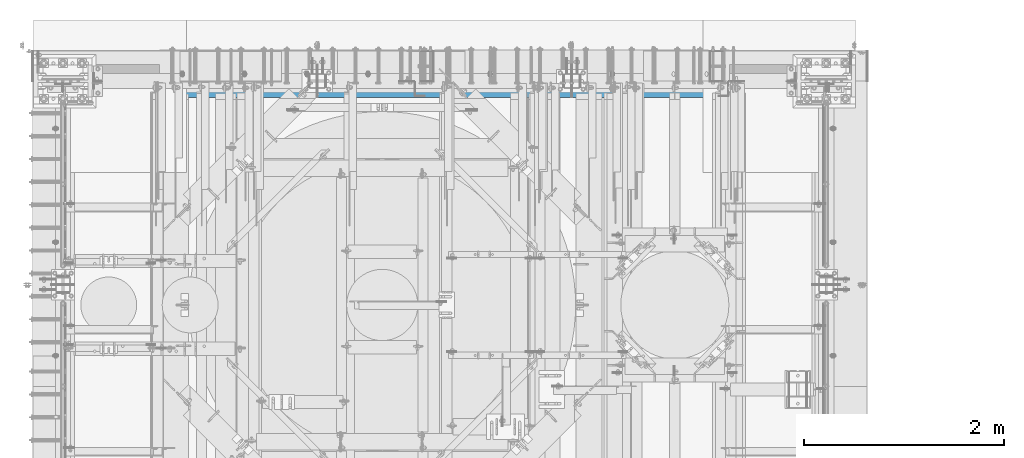
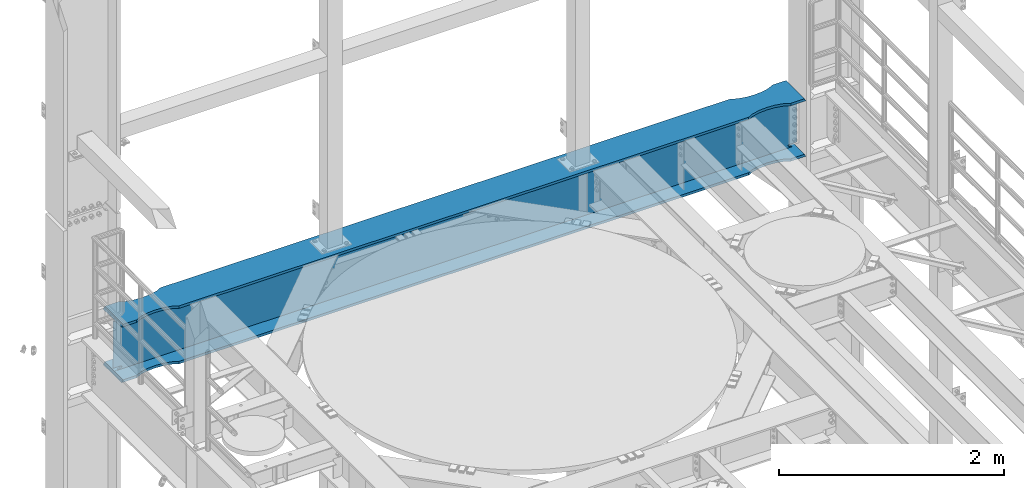
# One storey, part 1066 of 1876: 1 beam, 1 element without a shape of its own.
"""IFC2X3 building model written with IfcOpenShell, lengths in millimetres."""

from ifc_helpers import new_model, si_unit, frame, origin_with_axes, place, context, subcontext, project, spatial, faceted_brep, material, type_object, element, aggregate, save


model = new_model("IFC2X3")

# Units and contexts
model_context = context("Model", 3, precision=1e-05, world=origin_with_axes())
body_context = subcontext(model_context, "Body", "Model", "MODEL_VIEW")
ifc_project = project(units=[si_unit("LENGTHUNIT", "METRE", prefix="MILLI"), si_unit("AREAUNIT", "SQUARE_METRE"), si_unit("VOLUMEUNIT", "CUBIC_METRE"), si_unit("MASSUNIT", "GRAM", prefix="KILO"), si_unit("TIMEUNIT", "SECOND"), si_unit("PLANEANGLEUNIT", "RADIAN"), si_unit("SOLIDANGLEUNIT", "STERADIAN"), si_unit("THERMODYNAMICTEMPERATUREUNIT", "DEGREE_CELSIUS"), si_unit("LUMINOUSINTENSITYUNIT", "LUMEN")], contexts=[model_context])

# Site, building, storey
site_placement = place(None, origin_with_axes())
site = spatial("IfcSite", under=ifc_project, at=site_placement, CompositionType="ELEMENT")
building_placement = place(site_placement, origin_with_axes())
building = spatial("IfcBuilding", under=site, at=building_placement, Name="Undefined", CompositionType="ELEMENT")
storey_placement = place(building_placement, origin_with_axes())
storey = spatial("IfcBuildingStorey", under=building, at=storey_placement, Name="Undefined", CompositionType="ELEMENT", Elevation=0.0)

# Assembly, beam
assembly_placement = place(storey_placement, origin_with_axes())
assembly = element("IfcElementAssembly", 1, at=assembly_placement, inside=storey, Name="BEAM", AssemblyPlace="NOTDEFINED", PredefinedType="RIGID_FRAME")
ifc_material = material(Name="STEEL/A992")
beam_type = type_object("IfcBeamType", Name="W24X146", PredefinedType="NOTDEFINED")
beam_placement = place(assembly_placement, frame((0.0, 13716.0, 12995.275), z_axis=(0.0, 0.0, 1.0), x_axis=(1.0, 0.0, 0.0)))
beam = element("IfcBeam", 2, at=beam_placement, type_object=beam_type, material=ifc_material, Name="BEAM", ObjectType="W24X146", context=body_context, shape_type="Brep", body=[
    faceted_brep([(7318.375, -7.9375, -252.4125), (7308.85, 7.9375, -252.4125), (7308.85, 7.9375, 252.4125), (7318.375, -7.9375, 252.4125), (311.15, 7.9375, -252.4125), (301.625, -7.9375, -252.4125), (301.625, -7.9375, 252.4125), (311.15, 7.9375, 252.4125), (6787.05722612347, 136.155854771378, 314.325000000001), (6787.05722612347, 136.155854771378, 287.3375), (6731.00000871499, 163.5125, 287.3375), (6731.00000871499, 163.512500299129, 314.325000000001), (6787.48805720929, 135.961267957882, 314.325000000001), (6787.48805720929, 135.961267957882, 287.3375), (6787.92970812774, 135.792674011595, 314.325000000001), (6787.92970812774, 135.792674011595, 287.3375), (6788.3806123108, 135.650670947547, 314.325000000001), (6788.3806123108, 135.650670947547, 287.3375), (6788.83917036842, 135.535762460966, 314.325000000001), (6788.83917036842, 135.535762460966, 287.3375), (6866.57612824297, 118.499041238055, 314.325000000001), (6866.57612824297, 118.499041238055, 287.3375), (6946.90001329237, 112.712500184298, 314.325000000001), (6946.90001329237, 112.712500184298, 287.3375), (7027.22389842007, 118.4990401514, 314.325000000001), (7027.22389842007, 118.4990401514, 287.3375), (7105.88894087753, 135.739157957359, 314.325000000001), (7105.88894087753, 135.739157957359, 287.3375), (7162.80000000007, 163.512504557366, 314.325000000001), (7162.80000000007, 163.5125, 287.3375), (6787.05722612347, 136.155854771378, -287.3375), (6787.05722612347, 136.155854771378, -314.325000000001), (6731.00000871499, 163.5125, -314.325000000001), (6731.00000871499, 163.512500299129, -287.3375), (6787.48805720929, 135.961267957882, -287.3375), (6787.48805720929, 135.961267957882, -314.325000000001), (6787.92970812774, 135.792674011595, -287.3375), (6787.92970812774, 135.792674011595, -314.325000000001), (6788.3806123108, 135.650670947547, -287.3375), (6788.3806123108, 135.650670947547, -314.325000000001), (6788.83917036842, 135.535762460966, -287.3375), (6788.83917036842, 135.535762460966, -314.325000000001), (6866.57612824297, 118.499041238055, -287.3375), (6866.57612824297, 118.499041238055, -314.325000000001), (6946.90001329237, 112.712500184298, -287.3375), (6946.90001329237, 112.712500184298, -314.325000000001), (7027.22389842007, 118.4990401514, -287.3375), (7027.22389842007, 118.4990401514, -314.325000000001), (7105.88894087753, 135.739157957359, -287.3375), (7105.88894087753, 135.739157957359, -314.325000000001), (7162.80000000007, 163.512504557366, -287.3375), (7162.80000000007, 163.5125, -314.325000000001), (7162.80000000007, -163.512501991139, -287.3375), (7162.80000000007, -163.5125, -314.325000000001), (7318.375, -163.5125, -314.325000000001), (7302.79341467604, -163.512500199422, -287.3375), (7162.80000000007, -163.512501991139, 314.325000000001), (7162.80000000007, -163.5125, 287.3375), (7318.375, -163.5125, 287.3375), (7302.79342652469, -163.512500199422, 314.325000000001), (7265.82200317383, -7.9375, -286.94049987793), (7265.82200317383, 7.9375, -286.94049987793), (7230.34974885072, 7.9375, -270.587562630286), (7230.34974885072, -7.9375, -270.587562630286), (7226.45954094452, 7.9375, -267.291342989443), (7226.45954094452, -7.9375, -267.291342989443), (7224.82687519741, 7.9375, -262.460899528196), (7224.82687519741, -7.9375, -262.460899528196), (7225.91961637614, 7.9375, -257.48046800167), (7225.91961637614, -7.9375, -257.48046800167), (7229.42462316711, 7.9375, -253.777265486369), (7229.42462316711, -7.9375, -253.777265486369), (7234.33748349907, 7.9375, -252.4125), (7234.33748349907, -7.9375, -252.4125), (7234.50248497622, 7.9375, 252.4125), (7234.50248497622, -7.9375, 252.4125), (7229.58962470748, 7.9375, 253.777265448316), (7229.58962470748, -7.9375, 253.777265448316), (7226.08461792234, 7.9375, 257.480467871263), (7226.08461792234, -7.9375, 257.480467871263), (7224.9918766624, 7.9375, 262.460899307192), (7224.9918766624, -7.9375, 262.460899307192), (7226.6245422558, 7.9375, 267.291342745357), (7226.6245422558, -7.9375, 267.291342745357), (7230.51474999286, 7.9375, 270.587562475843), (7230.51474999286, -7.9375, 270.587562475843), (7265.9870010376, 7.9375, 286.94049987793), (7265.9870010376, -7.9375, 286.94049987793), (7318.375, 7.9375, 286.94049987793), (7318.375, -7.9375, 286.94049987793), (7318.375, 7.9375, 287.3375), (7318.375, -7.9375, 287.3375), (7318.375, 163.5125, 287.3375), (7302.79342652469, 163.512500456442, 314.325000000001), (457.199999305522, 163.5125, 314.325000000001), (457.199999305522, 163.5125, 287.3375), (301.625, 163.5125, 287.3375), (317.206573475306, 163.5125, 314.325000000001), (513.257216713985, 136.155853488265, 314.325000000001), (513.257216713985, 136.155853488265, 287.3375), (513.688047799806, 135.961266674769, 314.325000000001), (513.688047799806, 135.961266674769, 287.3375), (514.12969871826, 135.792672728482, 314.325000000001), (514.12969871826, 135.792672728482, 287.3375), (514.580602901315, 135.650669664434, 314.325000000001), (514.580602901315, 135.650669664434, 287.3375), (515.039160958935, 135.535761177853, 314.325000000001), (515.039160958935, 135.535761177853, 287.3375), (592.776118833464, 118.499039954942, 314.325000000001), (592.776118833464, 118.499039954942, 287.3375), (673.100003882856, 112.712498901185, 314.325000000001), (673.100003882856, 112.712498901185, 287.3375), (753.423889010533, 118.499038868286, 314.325000000001), (753.423889010533, 118.499038868286, 287.3375), (832.088931467987, 135.739156674245, 314.325000000001), (832.088931467987, 135.739156674245, 287.3375), (888.999990590519, 163.512503274253, 314.325000000001), (888.999990590519, 163.5125, 287.3375), (301.625, 7.9375, 287.3375), (317.206573475306, -163.5125, 314.325000000001), (457.199999305522, -163.5125, 314.325000000001), (513.257216713985, -136.155853488265, 314.325000000001), (513.688047799806, -135.961266674769, 314.325000000001), (514.12969871826, -135.792672728482, 314.325000000001), (514.580602901315, -135.650669664434, 314.325000000001), (515.039160958935, -135.535761177853, 314.325000000001), (592.776118833464, -118.499039954942, 314.325000000001), (673.100003882856, -112.712498901185, 314.325000000001), (753.423889010533, -118.499038868286, 314.325000000001), (832.088931467987, -135.739156674245, 314.325000000001), (888.999990590519, -163.512503274253, 314.325000000001), (6731.00000871499, -163.512500299129, 314.325000000001), (6787.05722612347, -136.155852205152, 314.325000000001), (6787.48805720929, -135.961265391656, 314.325000000001), (6787.92970812774, -135.792671445369, 314.325000000001), (6788.3806123108, -135.65066838132, 314.325000000001), (6788.83917036842, -135.535759894739, 314.325000000001), (6866.57612824297, -118.499038671828, 314.325000000001), (6946.90001329237, -112.712497618071, 314.325000000001), (7027.22389842007, -118.499037585173, 314.325000000001), (7105.88894087753, -135.739155391132, 314.325000000001), (457.199999305522, -163.5125, 287.3375), (301.625, -163.5125, 287.3375), (513.257216713985, -136.155853488265, 287.3375), (513.688047799806, -135.961266674769, 287.3375), (514.12969871826, -135.792672728482, 287.3375), (514.580602901315, -135.650669664434, 287.3375), (515.039160958935, -135.535761177853, 287.3375), (592.776118833464, -118.499039954942, 287.3375), (673.100003882856, -112.712498901185, 287.3375), (753.423889010533, -118.499038868286, 287.3375), (832.088931467987, -135.739156674245, 287.3375), (888.999990590519, -163.5125, 287.3375), (6731.00000871499, -163.5125, 287.3375), (6787.05722612347, -136.155852205152, 287.3375), (6787.48805720929, -135.961265391656, 287.3375), (6787.92970812774, -135.792671445369, 287.3375), (6788.3806123108, -135.65066838132, 287.3375), (6788.83917036842, -135.535759894739, 287.3375), (6866.57612824297, -118.499038671828, 287.3375), (6946.90001329237, -112.712497618071, 287.3375), (7027.22389842007, -118.499037585173, 287.3375), (7105.88894087753, -135.739155391132, 287.3375), (301.625, -7.9375, 287.3375), (301.625, 7.9375, 286.94049987793), (301.625, -7.9375, 286.94049987793), (354.012998962403, 7.9375, 286.94049987793), (354.012998962403, -7.9375, 286.94049987793), (389.485250007137, 7.9375, 270.587562475845), (389.485250007137, -7.9375, 270.587562475845), (393.375457744202, 7.9375, 267.291342745357), (393.375457744202, -7.9375, 267.291342745357), (395.008123337595, 7.9375, 262.460899307192), (395.008123337595, -7.9375, 262.460899307192), (393.915382077658, 7.9375, 257.480467871263), (393.915382077658, -7.9375, 257.480467871263), (390.410375292523, 7.9375, 253.777265448314), (390.410375292523, -7.9375, 253.777265448314), (385.497515023773, 7.9375, 252.412500000002), (385.497515023773, -7.9375, 252.412500000002), (385.66251650093, 7.9375, -252.4125), (385.66251650093, -7.9375, -252.4125), (390.575376832887, 7.9375, -253.777265486369), (390.575376832887, -7.9375, -253.777265486369), (394.08038362386, 7.9375, -257.48046800167), (394.08038362386, -7.9375, -257.48046800167), (395.173124802588, 7.9375, -262.460899528196), (395.173124802588, -7.9375, -262.460899528196), (393.540459055476, 7.9375, -267.291342989443), (393.540459055476, -7.9375, -267.291342989443), (389.650251149281, 7.9375, -270.587562630286), (389.650251149281, -7.9375, -270.587562630286), (354.177996826172, 7.9375, -286.94049987793), (354.177996826172, -7.9375, -286.94049987793), (317.435792427282, 7.9375, -286.94049987793), (317.435792427282, -7.9375, -286.94049987793), (7302.79341467604, -7.9375, -287.3375), (7302.56420757272, -7.9375, -286.94049987793), (317.206585323961, -7.9375, -287.3375), (7302.56420757272, 7.9375, -286.94049987793), (7302.79341467604, 7.9375, -287.3375), (317.206585323961, 7.9375, -287.3375), (888.999990590519, 163.512503274253, -287.3375), (888.999990590519, 163.5125, -314.325000000001), (832.088931467987, 135.739156674245, -314.325000000001), (832.088931467987, 135.739156674245, -287.3375), (753.423889010533, 118.499038868286, -314.325000000001), (753.423889010533, 118.499038868286, -287.3375), (673.100003882856, 112.712498901185, -314.325000000001), (673.100003882856, 112.712498901185, -287.3375), (592.776118833464, 118.499039954942, -314.325000000001), (592.776118833464, 118.499039954942, -287.3375), (515.039160958935, 135.535761177853, -314.325000000001), (515.039160958935, 135.535761177853, -287.3375), (514.580602901315, 135.650669664434, -314.325000000001), (514.580602901315, 135.650669664434, -287.3375), (514.12969871826, 135.792672728482, -314.325000000001), (514.12969871826, 135.792672728482, -287.3375), (513.688047799806, 135.961266674769, -314.325000000001), (513.688047799806, 135.961266674769, -287.3375), (513.257216713985, 136.155853488265, -314.325000000001), (513.257216713985, 136.155853488265, -287.3375), (457.199999305522, 163.5125, -314.325000000001), (457.199999305522, 163.5125, -287.3375), (301.625, 163.5125, -314.325000000001), (317.206585323961, 163.5125, -287.3375), (301.625, -163.5125, -314.325000000001), (317.206585323961, -163.5125, -287.3375), (457.199999305522, -163.5125, -314.325000000001), (457.199999305522, -163.5125, -287.3375), (513.257216713985, -136.155853488265, -314.325000000001), (513.257216713985, -136.155853488265, -287.3375), (513.688047799806, -135.961266674769, -314.325000000001), (513.688047799806, -135.961266674769, -287.3375), (514.12969871826, -135.792672728482, -314.325000000001), (514.12969871826, -135.792672728482, -287.3375), (514.580602901315, -135.650669664434, -314.325000000001), (514.580602901315, -135.650669664434, -287.3375), (515.039160958935, -135.535761177853, -314.325000000001), (515.039160958935, -135.535761177853, -287.3375), (592.776118833464, -118.499039954942, -314.325000000001), (592.776118833464, -118.499039954942, -287.3375), (673.100003882856, -112.712498901185, -314.325000000001), (673.100003882856, -112.712498901185, -287.3375), (753.423889010533, -118.499038868286, -314.325000000001), (753.423889010533, -118.499038868286, -287.3375), (832.088931467987, -135.739156674245, -314.325000000001), (832.088931467987, -135.739156674245, -287.3375), (888.999990590519, -163.512503274253, -287.3375), (888.999990590519, -163.5125, -314.325000000001), (6731.00000871499, -163.5125, -314.325000000001), (6731.00000871499, -163.512500299129, -287.3375), (6787.05722612347, -136.155852205152, -314.325000000001), (6787.05722612347, -136.155852205152, -287.3375), (6787.48805720929, -135.961265391656, -314.325000000001), (6787.48805720929, -135.961265391656, -287.3375), (6787.92970812774, -135.792671445369, -314.325000000001), (6787.92970812774, -135.792671445369, -287.3375), (6788.3806123108, -135.65066838132, -314.325000000001), (6788.3806123108, -135.65066838132, -287.3375), (6788.83917036842, -135.535759894739, -314.325000000001), (6788.83917036842, -135.535759894739, -287.3375), (6866.57612824297, -118.499038671828, -314.325000000001), (6866.57612824297, -118.499038671828, -287.3375), (6946.90001329237, -112.712497618071, -314.325000000001), (6946.90001329237, -112.712497618071, -287.3375), (7027.22389842007, -118.499037585173, -314.325000000001), (7027.22389842007, -118.499037585173, -287.3375), (7105.88894087753, -135.739155391132, -314.325000000001), (7105.88894087753, -135.739155391132, -287.3375), (7318.375, 163.5125, -314.325000000001), (7302.79341467604, 163.512500456442, -287.3375)], [[[0, 1, 2, 3]], [[4, 5, 6, 7]], [[8, 9, 10, 11]], [[12, 13, 9, 8]], [[14, 15, 13, 12]], [[16, 17, 15, 14]], [[18, 19, 17, 16]], [[20, 21, 19, 18]], [[22, 23, 21, 20]], [[24, 25, 23, 22]], [[26, 27, 25, 24]], [[28, 29, 27, 26]], [[30, 31, 32, 33]], [[34, 35, 31, 30]], [[36, 37, 35, 34]], [[38, 39, 37, 36]], [[40, 41, 39, 38]], [[42, 43, 41, 40]], [[44, 45, 43, 42]], [[46, 47, 45, 44]], [[48, 49, 47, 46]], [[50, 51, 49, 48]], [[52, 53, 54, 55]], [[56, 57, 58, 59]], [[60, 61, 62, 63]], [[63, 62, 64, 65]], [[65, 64, 66, 67]], [[67, 66, 68, 69]], [[69, 68, 70, 71]], [[71, 70, 72, 73]], [[73, 72, 1, 0]], [[74, 75, 3, 2]], [[75, 74, 76, 77]], [[77, 76, 78, 79]], [[79, 78, 80, 81]], [[81, 80, 82, 83]], [[83, 82, 84, 85]], [[85, 84, 86, 87]], [[87, 86, 88, 89]], [[89, 88, 90, 91]], [[58, 91, 90, 92, 93, 59]], [[94, 95, 96, 97]], [[98, 99, 95, 94]], [[100, 101, 99, 98]], [[102, 103, 101, 100]], [[104, 105, 103, 102]], [[106, 107, 105, 104]], [[108, 109, 107, 106]], [[110, 111, 109, 108]], [[112, 113, 111, 110]], [[114, 115, 113, 112]], [[116, 117, 115, 114]], [[117, 116, 11, 10]], [[118, 96, 95, 99, 101, 103, 105, 107, 109, 111, 113, 115, 117, 10, 9, 13, 15, 17, 19, 21, 23, 25, 27, 29, 92, 90]], [[29, 28, 93, 92]], [[28, 26, 24, 22, 20, 18, 16, 14, 12, 8, 11, 116, 114, 112, 110, 108, 106, 104, 102, 100, 98, 94, 97, 119, 120, 121, 122, 123, 124, 125, 126, 127, 128, 129, 130, 131, 132, 133, 134, 135, 136, 137, 138, 139, 140, 56, 59, 93]], [[141, 120, 119, 142]], [[120, 141, 143, 121]], [[121, 143, 144, 122]], [[122, 144, 145, 123]], [[123, 145, 146, 124]], [[124, 146, 147, 125]], [[125, 147, 148, 126]], [[126, 148, 149, 127]], [[127, 149, 150, 128]], [[128, 150, 151, 129]], [[130, 129, 151, 152]], [[130, 152, 153, 131]], [[131, 153, 154, 132]], [[132, 154, 155, 133]], [[133, 155, 156, 134]], [[134, 156, 157, 135]], [[135, 157, 158, 136]], [[136, 158, 159, 137]], [[137, 159, 160, 138]], [[138, 160, 161, 139]], [[139, 161, 162, 140]], [[56, 140, 162, 57]], [[57, 162, 161, 160, 159, 158, 157, 156, 155, 154, 153, 152, 151, 150, 149, 148, 147, 146, 145, 144, 143, 141, 142, 163, 91, 58]], [[119, 97, 96, 118, 163, 142]], [[164, 165, 163, 118]], [[166, 167, 165, 164]], [[167, 166, 168, 169]], [[169, 168, 170, 171]], [[171, 170, 172, 173]], [[173, 172, 174, 175]], [[175, 174, 176, 177]], [[177, 176, 178, 179]], [[179, 178, 7, 6]], [[180, 181, 5, 4]], [[181, 180, 182, 183]], [[183, 182, 184, 185]], [[185, 184, 186, 187]], [[187, 186, 188, 189]], [[189, 188, 190, 191]], [[191, 190, 192, 193]], [[193, 192, 194, 195]], [[196, 197, 60, 63, 65, 67, 69, 71, 73, 0, 3, 75, 77, 79, 81, 83, 85, 87, 89, 91, 163, 165, 167, 169, 171, 173, 175, 177, 179, 6, 5, 181, 183, 185, 187, 189, 191, 193, 195, 198]], [[61, 60, 197, 199]], [[72, 70, 68, 66, 64, 62, 61, 199, 200, 201, 194, 192, 190, 188, 186, 184, 182, 180, 4, 7, 178, 176, 174, 172, 170, 168, 166, 164, 118, 90, 88, 86, 84, 82, 80, 78, 76, 74, 2, 1]], [[202, 203, 204, 205]], [[205, 204, 206, 207]], [[207, 206, 208, 209]], [[209, 208, 210, 211]], [[211, 210, 212, 213]], [[213, 212, 214, 215]], [[215, 214, 216, 217]], [[217, 216, 218, 219]], [[219, 218, 220, 221]], [[221, 220, 222, 223]], [[223, 222, 224, 225]], [[195, 194, 201, 225, 224, 226, 227, 198]], [[228, 229, 227, 226]], [[229, 228, 230, 231]], [[231, 230, 232, 233]], [[233, 232, 234, 235]], [[235, 234, 236, 237]], [[237, 236, 238, 239]], [[239, 238, 240, 241]], [[241, 240, 242, 243]], [[243, 242, 244, 245]], [[245, 244, 246, 247]], [[248, 247, 246, 249]], [[248, 249, 250, 251]], [[251, 250, 252, 253]], [[253, 252, 254, 255]], [[255, 254, 256, 257]], [[257, 256, 258, 259]], [[259, 258, 260, 261]], [[261, 260, 262, 263]], [[263, 262, 264, 265]], [[265, 264, 266, 267]], [[267, 266, 268, 269]], [[52, 269, 268, 53]], [[198, 227, 229, 231, 233, 235, 237, 239, 241, 243, 245, 247, 248, 251, 253, 255, 257, 259, 261, 263, 265, 267, 269, 52, 55, 196]], [[54, 270, 271, 200, 199, 197, 196, 55]], [[50, 48, 46, 44, 42, 40, 38, 36, 34, 30, 33, 202, 205, 207, 209, 211, 213, 215, 217, 219, 221, 223, 225, 201, 200, 271]], [[203, 202, 33, 32]], [[53, 268, 266, 264, 262, 260, 258, 256, 254, 252, 250, 249, 246, 244, 242, 240, 238, 236, 234, 232, 230, 228, 226, 224, 222, 220, 218, 216, 214, 212, 210, 208, 206, 204, 203, 32, 31, 35, 37, 39, 41, 43, 45, 47, 49, 51, 270, 54]], [[51, 50, 271, 270]]]),
])
aggregate(assembly, [beam])

save(model, "model.ifc")
